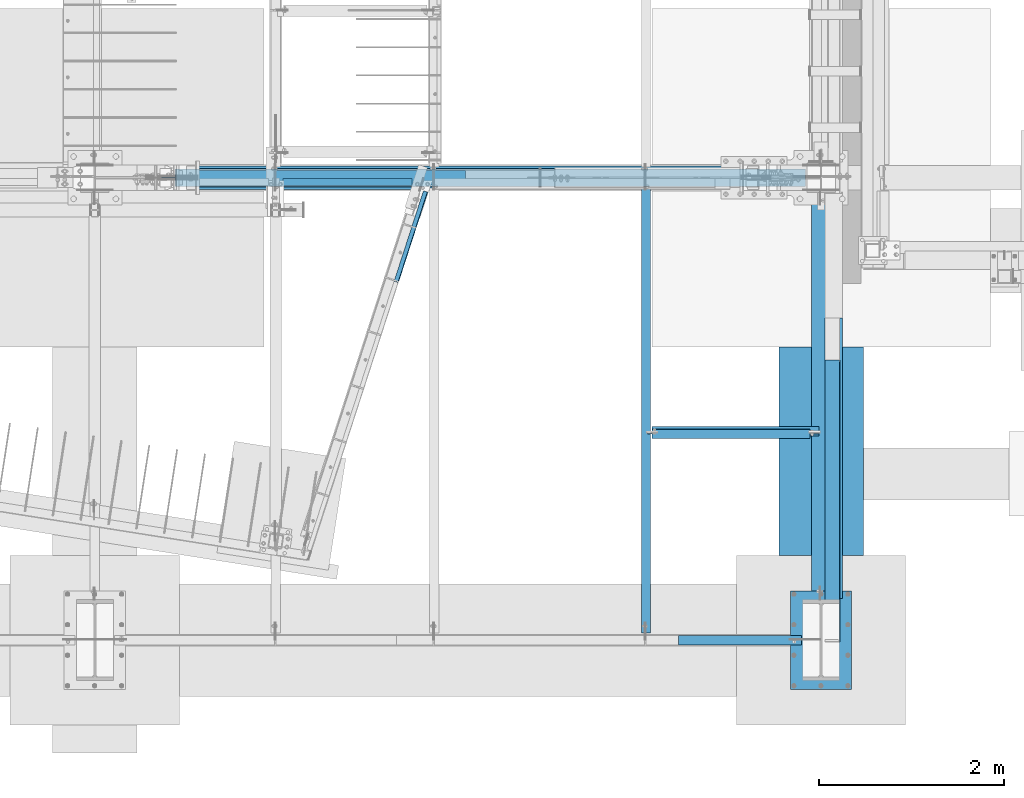
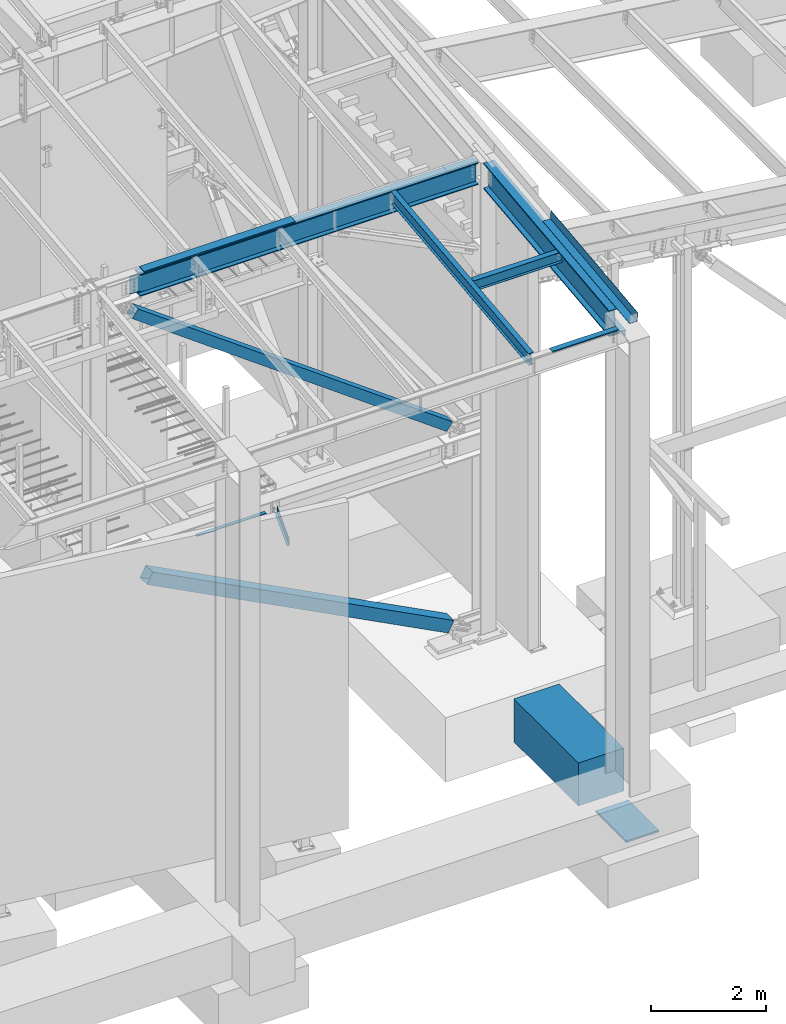
# One storey, part 715 of 1179: 12 beams, 2 members, 11 elements without a shape of their own.
"""IFC2X3 building model written with IfcOpenShell, lengths in millimetres."""

from ifc_helpers import new_model, si_unit, frame, origin_with_axes, place, context, subcontext, project, spatial, faceted_brep, material, type_object, element, aggregate, save


model = new_model("IFC2X3")

# Units and contexts
model_context = context("Model", 3, precision=1e-05, world=origin_with_axes())
body_context = subcontext(model_context, "Body", "Model", "MODEL_VIEW")
ifc_project = project(units=[si_unit("LENGTHUNIT", "METRE", prefix="MILLI"), si_unit("AREAUNIT", "SQUARE_METRE"), si_unit("VOLUMEUNIT", "CUBIC_METRE"), si_unit("MASSUNIT", "GRAM", prefix="KILO"), si_unit("TIMEUNIT", "SECOND"), si_unit("PLANEANGLEUNIT", "RADIAN"), si_unit("SOLIDANGLEUNIT", "STERADIAN"), si_unit("THERMODYNAMICTEMPERATUREUNIT", "DEGREE_CELSIUS"), si_unit("LUMINOUSINTENSITYUNIT", "LUMEN")], contexts=[model_context])

# Site, building, storey
site_placement = place(None, origin_with_axes())
site = spatial("IfcSite", under=ifc_project, at=site_placement, CompositionType="ELEMENT")
building_placement = place(site_placement, origin_with_axes())
building = spatial("IfcBuilding", under=site, at=building_placement, Name="Undefined", CompositionType="ELEMENT")
storey_placement = place(building_placement, origin_with_axes())
storey = spatial("IfcBuildingStorey", under=building, at=storey_placement, Name="Undefined", CompositionType="ELEMENT", Elevation=0.0)

# Assembly, beam
assembly_1_placement = place(storey_placement, origin_with_axes())
assembly_1 = element("IfcElementAssembly", 1, at=assembly_1_placement, inside=storey, Name="BEAM", AssemblyPlace="NOTDEFINED", PredefinedType="RIGID_FRAME")
ifc_material_1 = material(Name="STEEL/A36")
beam_type_1 = type_object("IfcBeamType", PredefinedType="NOTDEFINED")
beam_1_placement = place(assembly_1_placement, frame((18943.6380023565, 5508.63433466315, 9826.91628425202), z_axis=(-1.0, 0.0, 0.0), x_axis=(0.0, 0.0, 1.0)))
beam_1 = element("IfcBeam", 2, at=beam_1_placement, type_object=beam_type_1, material=ifc_material_1, Name="BENT_PLATE", context=body_context, shape_type="Brep", body=[
    faceted_brep([(-2.91038304567337e-11, -4.76250000000073, -1524.0), (-2.91038304567337e-11, -4.76250000000073, 1524.0), (2.91038304567337e-11, 4.76250000000073, 1524.0), (2.91038304567337e-11, 4.76250000000073, -1524.0), (42.9704233942375, 4.76249999974698, 1524.0), (42.9704233942375, 4.76249999974698, -1524.0), (32.3091293704474, -4.7625000001899, -1524.0), (32.3091293704474, -4.7625000001899, 1524.0), (25.4000000272608, -150.812499999743, 1524.0), (25.4000000272608, -150.812499999743, -1524.0), (16.8901864157524, -141.287499999744, -1524.0), (16.8901864157524, -141.287499999744, 1524.0), (8.54161044117063e-08, -150.812499999749, 1524.0), (8.54161044117063e-08, -150.812499999749, -1524.0), (8.54161044117063e-08, -141.287499999748, 1524.0), (8.54161044117063e-08, -141.287499999748, -1524.0)], [[[0, 1, 2, 3]], [[3, 2, 4, 5]], [[1, 0, 6, 7]], [[5, 4, 8, 9]], [[7, 6, 10, 11]], [[9, 8, 12, 13]], [[8, 4, 2, 1, 7, 11, 14, 12]], [[11, 10, 15, 14]], [[10, 6, 0, 3, 5, 9, 13, 15]], [[14, 15, 13, 12]]]),
])

assembly_2_placement = place(storey_placement, origin_with_axes())
assembly_2 = element("IfcElementAssembly", 3, at=assembly_2_placement, inside=storey, Name="BEAM", AssemblyPlace="NOTDEFINED", PredefinedType="RIGID_FRAME")
beam_type_2 = type_object("IfcBeamType", PredefinedType="NOTDEFINED")
beam_2_placement = place(assembly_2_placement, frame((19851.8875005852, 4805.93541535661, 3851.275), z_axis=(0.308737244064257, 0.951147367197958, 0.0), x_axis=(0.951147370126809, -0.30873723504115, 0.0)))
beam_2 = element("IfcBeam", 4, at=beam_2_placement, type_object=beam_type_2, material=ifc_material_1, Name="BENT_PLATE", context=body_context, shape_type="Brep", body=[
    faceted_brep([(-5.45696821063757e-11, -3.17500000000018, -514.350000000124), (6.18456397205591e-11, -3.17500000000018, 514.350000000128), (6.18456397205591e-11, 3.17500000000018, 514.350000000128), (-5.45696821063757e-11, 3.17500000000018, -514.350000000124), (50.8000003755697, 3.17500000000018, 514.35000000018), (50.8000003756788, 3.17500000000018, -514.350000000071), (44.4500003756766, -3.17500000000018, -514.350000000079), (44.4500003755638, -3.17500000000018, 514.350000000175), (50.8000003757079, -130.175006105127, 514.35000000021), (50.8000003755405, -130.17500610536, -514.350000000044), (44.4500003757021, -130.175006105127, 514.350000000204), (44.4500003755384, -130.17500610536, -514.350000000048)], [[[0, 1, 2, 3]], [[3, 2, 4, 5]], [[1, 0, 6, 7]], [[5, 4, 8, 9]], [[4, 2, 1, 7, 10, 8]], [[7, 6, 11, 10]], [[6, 0, 3, 5, 9, 11]], [[10, 11, 9, 8]]]),
])
aggregate(assembly_2, [beam_2])

assembly_3_placement = place(storey_placement, origin_with_axes())
assembly_3 = element("IfcElementAssembly", 5, at=assembly_3_placement, inside=storey, Name="BEAM", AssemblyPlace="NOTDEFINED", PredefinedType="RIGID_FRAME")
ifc_material_2 = material(Name="STEEL/A992")
beam_type_3 = type_object("IfcBeamType", Name="W10X12", PredefinedType="NOTDEFINED")
beam_3_placement = place(assembly_3_placement, frame((22415.5, 2681.08182806571, 9423.63694249416), z_axis=(0.0, -0.112284087038017, 0.993676146336441), x_axis=(1.0, 0.0, 0.0)))
beam_3 = element("IfcBeam", 6, at=beam_3_placement, type_object=beam_type_3, material=ifc_material_2, Name="BEAM", ObjectType="W10X12", context=body_context, shape_type="Brep", body=[
    faceted_brep([(14.2874999999985, -2.38124999999445, -103.187499998467), (14.2874999999985, 2.38125000000446, -103.187499998467), (50.8000001907421, 2.38125000000446, -103.18749999841), (50.8000001907421, -2.38124999999445, -103.187499998403), (55.6600797087885, 2.38125000000491, -104.154229920996), (55.6600797087885, -2.38124999999445, -104.154229920992), (59.7802561769422, 2.38125000000491, -106.907243821472), (59.7802561769422, -2.38124999999445, -106.907243821464), (62.5332700774197, 2.38125000000537, -111.027420289618), (62.5332700774197, -2.38124999999445, -111.027420289613), (63.5000000000073, -2.381249999994, -115.887499807652), (63.5000000000073, 2.38125000000537, -115.887499807655), (63.5000000000073, 2.38125000000537, -120.64999999994), (63.5000000000073, 50.8000000000006, -120.649999999963), (63.5000000000073, 50.8000000000006, -125.412499999959), (63.5000000000073, -50.7999999999884, -125.412499999913), (63.5000000000073, -50.7999999999888, -120.649999999914), (63.5000000000073, -2.381249999994, -120.649999999938), (147.63725, 50.7999999999897, 120.649999999914), (1773.2375, 50.7999999999897, 120.649999999914), (1773.2375, 2.38124999999445, 120.649999999938), (63.5000000000073, 2.38124999999445, 120.649999999938), (63.5000000000073, 50.7999999999897, 120.649999999914), (50.8000001907421, -2.381250000004, 103.187500001295), (50.8000001907421, 2.38124999999536, 103.18750000129), (14.2874999999985, 2.38124999999536, 103.187500001235), (14.2874999999985, -2.38125000000446, 103.187500001233), (55.6600797087885, -2.38125000000446, 104.154229923881), (55.6600797087885, 2.38124999999536, 104.154229923877), (59.7802561769422, -2.38125000000446, 106.907243824357), (59.7802561769422, 2.38124999999491, 106.907243824349), (62.5332700774197, -2.38125000000446, 111.027420292501), (62.5332700774197, 2.38124999999536, 111.027420292499), (63.5000000000073, -2.38125000000446, 115.88749981054), (63.5000000000073, 2.38124999999445, 115.887499810537), (1773.2375, -50.8000000000002, 125.41249999996), (1773.2375, 50.7999999999888, 125.412499999913), (63.5000000000073, 50.7999999999888, 125.412499999913), (63.5000000000073, -50.8000000000002, 125.41249999996), (1773.2375, -50.7999999999997, 120.649999999963), (63.5000000000073, -50.7999999999997, 120.649999999963), (1773.2375, -2.38125000000537, 120.64999999994), (63.5000000000073, -2.38125000000537, 120.64999999994), (1773.2375, -2.38125000000355, 100.012499809063), (1773.2375, 2.38124999999491, 100.012499809058), (1774.20422992259, -2.38125000000446, 95.1524202910259), (1774.20422992259, 2.38124999999536, 95.1524202910186), (1776.95724382307, -2.38125000000355, 91.0322438228777), (1776.95724382307, 2.38124999999627, 91.0322438228723), (1781.07742029122, -2.38125000000355, 88.2792299224038), (1781.07742029122, 2.38124999999582, 88.2792299223984), (1785.93749980927, -2.38125000000355, 87.3124999998163), (1785.93749980927, 2.38124999999536, 87.3124999998126), (1871.6625, -2.38125000000355, 87.3124999998727), (1871.6625, 2.38124999999536, 87.3124999998745), (1871.6625, -2.381249999994, -120.649999999938), (1871.6625, -50.7999999999888, -120.649999999914), (1871.6625, -50.7999999999884, -125.412499999913), (1871.6625, 50.8000000000006, -125.412499999959), (1871.6625, 50.8000000000006, -120.649999999963), (1871.6625, 2.38125000000537, -120.64999999994)], [[[0, 1, 2, 3]], [[3, 2, 4, 5]], [[5, 4, 6, 7]], [[7, 6, 8, 9]], [[10, 11, 12, 13, 14, 15, 16, 17]], [[9, 8, 11, 10]], [[18, 19, 20, 21, 22]], [[23, 24, 25, 26]], [[27, 28, 24, 23]], [[29, 30, 28, 27]], [[31, 32, 30, 29]], [[33, 34, 32, 31]], [[35, 36, 37, 38]], [[39, 35, 38, 40]], [[41, 39, 40, 42]], [[38, 37, 22, 21, 34, 33, 42, 40]], [[36, 19, 18, 22, 37]], [[35, 39, 41, 43, 44, 20, 19, 36]], [[45, 46, 44, 43]], [[47, 48, 46, 45]], [[49, 50, 48, 47]], [[51, 52, 50, 49]], [[53, 54, 52, 51]], [[55, 56, 57, 58, 59, 60, 54, 53]], [[56, 55, 17, 16]], [[57, 56, 16, 15]], [[58, 57, 15, 14]], [[59, 58, 14, 13]], [[60, 59, 13, 12]], [[6, 4, 2, 1, 25, 24, 28, 30, 32, 34, 21, 20, 44, 46, 48, 50, 52, 54, 60, 12, 11, 8]], [[26, 25, 1, 0]], [[55, 53, 51, 49, 47, 45, 43, 41, 42, 33, 31, 29, 27, 23, 26, 0, 3, 5, 7, 9, 10, 17]]]),
])
aggregate(assembly_3, [beam_3])

assembly_4_placement = place(storey_placement, origin_with_axes())
assembly_4 = element("IfcElementAssembly", 7, at=assembly_4_placement, inside=storey, Name="BEAM", AssemblyPlace="NOTDEFINED", PredefinedType="RIGID_FRAME")
beam_4_placement = place(assembly_4_placement, frame((22415.5, 452.231593993459, 9171.78056384809), z_axis=(-3.89779463887408e-08, -0.112282221021699, 0.993676357192035), x_axis=(0.0, 0.993676357192036, 0.112282221021699)))
beam_4 = element("IfcBeam", 8, at=beam_4_placement, type_object=beam_type_3, material=ifc_material_2, Name="BEAM", ObjectType="W10X12", context=body_context, shape_type="Brep", body=[
    faceted_brep([(4858.49015079339, 2.38124999999854, -120.649999999368), (4858.49015079341, 2.38119320135957, -125.412499999364), (4858.49013956012, 50.7999999999993, -125.412499999362), (4858.49013956012, 50.7999999999993, -120.649999999367), (4983.08589598448, 2.38124999999854, -120.649999999354), (4982.54774885665, 2.38122198294514, -125.412499999351), (48.8806597554974, -2.38124999999854, -120.649999999914), (48.8806597554974, -50.7999999999993, -120.649999999914), (4858.49016309746, -50.7999999999993, -120.649999999367), (4858.49015186424, -2.38124999999854, -120.649999999367), (76.1467808989316, 2.38124999999854, 120.649999999929), (76.1467808989316, 50.7999999999993, 120.649999999929), (4914.49585701086, 50.7999999999993, 120.650000000478), (4914.49585701086, 2.38124999999854, 120.650000000478), (48.3425126276663, -50.7999999999993, -125.412499999911), (76.1467808989316, -2.38124999999854, 120.649999999929), (76.1467808989316, -50.7999999999993, 120.649999999929), (76.6849280267622, -50.7999999999993, 125.412499999924), (76.6849280267622, 50.7999999999993, 125.412499999924), (48.8806597554974, 2.38124999999854, -120.649999999914), (48.8806597554974, 50.7999999999993, -120.649999999914), (48.3425126276663, 50.7999999999993, -125.412499999911), (4858.49016309746, -50.7999999999993, -125.412499999364), (4858.49015186426, -2.38130674932472, -125.412499999364), (4983.08589598448, -2.38124999999854, -120.649999999354), (4982.54774885665, -2.3812779679356, -125.412499999351), (4916.56631885514, -2.38124999999854, 69.1498492601459), (4912.78131142652, -2.38124999999854, 72.3480766489138), (4910.50832916744, -2.38124999999854, 76.7513131080195), (4910.0934130222, -2.38124999999854, 81.6892058020039), (4914.49585701086, -2.38124999999854, 120.650000000478), (4983.1719256045, -2.38124999999854, -119.888654181221), (5003.31510185873, -2.38124999999854, 58.3746347029464), (4921.28711838346, -2.38124999999854, 67.6435320696546), (4914.49585701086, -50.7999999999993, 120.650000000478), (4915.03400413869, -50.7999999999993, 125.412500000475), (4915.03400413869, 50.7999999999993, 125.412500000475), (4910.0934130222, 2.38124999999854, 81.6892058020039), (4910.50832916744, 2.38124999999854, 76.7513131080195), (4912.78131142652, 2.38124999999854, 72.3480766489138), (4916.56631885514, 2.38124999999854, 69.1498492601459), (4921.28711838346, 2.38124999999854, 67.6435320696546), (5003.31510185873, 2.38124999999854, 58.3746347029464), (4983.17191277243, 2.38124999999854, -119.888767742599)], [[[0, 1, 2, 3]], [[4, 5, 1, 0]], [[6, 7, 8, 9]], [[10, 11, 12, 13]], [[14, 7, 6, 15, 16, 17, 18, 11, 10, 19, 20, 21]], [[7, 14, 22, 8]], [[8, 22, 23, 9]], [[24, 9, 23, 25]], [[26, 27, 28, 29, 30, 15, 6, 9, 24, 31, 32, 33]], [[16, 15, 30, 34]], [[17, 16, 34, 35]], [[18, 17, 35, 36]], [[11, 18, 36, 12]], [[35, 34, 30, 29, 37, 13, 12, 36]], [[28, 38, 37, 29]], [[27, 39, 38, 28]], [[26, 40, 39, 27]], [[33, 41, 40, 26]], [[32, 42, 41, 33]], [[43, 4, 0, 19, 10, 13, 37, 38, 39, 40, 41, 42]], [[20, 19, 0, 3]], [[21, 20, 3, 2]], [[25, 23, 22, 14, 21, 2, 1, 5]], [[43, 42, 32, 31, 24, 25, 5, 4]]]),
])
aggregate(assembly_4, [beam_4])

assembly_5_placement = place(storey_placement, origin_with_axes())
assembly_5 = element("IfcElementAssembly", 9, at=assembly_5_placement, inside=storey, Name="BEAM", AssemblyPlace="NOTDEFINED", PredefinedType="RIGID_FRAME")
beam_type_4 = type_object("IfcBeamType", PredefinedType="NOTDEFINED")
beam_5_placement = place(assembly_5_placement, frame((24350.663, 1952.15627219184, 9470.67302837203), z_axis=(0.0, -0.993676357192036, -0.112282221021698), x_axis=(1.0, 0.0, 0.0)))
beam_5 = element("IfcBeam", 10, at=beam_5_placement, type_object=beam_type_4, material=ifc_material_1, Name="BENT_PLATE", context=body_context, shape_type="Brep", body=[
    faceted_brep([(0.0, -3.17499999999927, -1524.0), (6.00266503170133e-10, -3.17499999922438, 1524.00000000052), (6.00266503170133e-10, 3.17500000077416, 1524.00000000052), (0.0, 3.17499999999927, -1524.0), (153.987000024775, 3.17499999922438, 1524.00000000046), (153.987000022519, 3.17500000077052, -1524.00000000059), (160.337000000047, -3.17500000061591, -1523.99999999915), (160.336999999981, -3.17499999938082, 1523.99999999915), (153.987000000016, 187.325000000103, 1523.99999999907), (153.987000000016, 187.324999998867, -1523.99999999923), (160.337000000014, 187.325000000103, 1523.99999999907), (160.337000000014, 187.324999998867, -1523.99999999923)], [[[0, 1, 2, 3]], [[3, 2, 4, 5]], [[1, 0, 6, 7]], [[5, 4, 8, 9]], [[4, 2, 1, 7, 10, 8]], [[7, 6, 11, 10]], [[6, 0, 3, 5, 9, 11]], [[10, 11, 9, 8]]]),
])

# Assembly, member
assembly_6_placement = place(storey_placement, origin_with_axes())
assembly_6 = element("IfcElementAssembly", 11, at=assembly_6_placement, inside=storey, Name="None", AssemblyPlace="NOTDEFINED", PredefinedType="RIGID_FRAME")
member_type_1 = type_object("IfcMemberType", Name="HSS8X8X3/16", PredefinedType="NOTDEFINED")
member_1_placement = place(assembly_6_placement, frame((17229.9133529486, 5435.6, 9031.07902835531), z_axis=(0.0, -1.0, 0.0), x_axis=(0.807759850958799, 0.0, -0.589511681969932)))
member_1 = element("IfcMember", 12, at=member_1_placement, type_object=member_type_1, material=ifc_material_2, Name="None", ObjectType="HSS8X8X3/16", context=body_context, shape_type="Brep", body=[
    faceted_brep([(-3.63797880709171e-12, 96.8374999999978, -96.8375000000015), (-3.63797880709171e-12, -96.8374999999978, -96.8375000000015), (7834.63000001563, -96.8375000007909, -96.8374999999996), (7834.63000001565, 96.8374999992666, -96.8374999999996), (-3.63797880709171e-12, -96.8374999999978, 96.8375000000015), (7834.63000001563, -96.8375000007909, 96.8374999999996), (-3.63797880709171e-12, 96.8374999999978, 96.8375000000015), (7834.63000001565, 96.8374999992666, 96.8374999999996), (-3.63797880709171e-12, 101.599999999999, -101.599999999999), (-3.63797880709171e-12, 101.599999999999, 101.599999999999), (7834.63000001565, 101.599999999267, 101.6), (7834.63000001565, 101.599999999267, -101.6), (0.0, -101.599999999999, 101.599999999999), (7834.63000001562, -101.600000000792, 101.6), (0.0, -101.599999999999, -101.599999999999), (7834.63000001562, -101.600000000792, -101.6)], [[[0, 1, 2, 3]], [[1, 4, 5, 2]], [[4, 6, 7, 5]], [[6, 0, 3, 7]], [[8, 9, 10, 11]], [[9, 12, 13, 10]], [[12, 14, 15, 13]], [[14, 8, 11, 15]], [[13, 15, 11, 10], [5, 7, 3, 2]], [[14, 12, 9, 8], [6, 4, 1, 0]]]),
])
aggregate(assembly_6, [member_1])

# Beam
beam_type_5 = type_object("IfcBeamType", PredefinedType="NOTDEFINED")
beam_6_placement = place(assembly_5_placement, frame((24350.6629997969, 2403.71894899032, 8992.89453938396), z_axis=(0.0, -0.993676146336441, -0.112284087038017), x_axis=(1.0, 0.0, 0.0)))
beam_6 = element("IfcBeam", 13, at=beam_6_placement, type_object=beam_type_5, material=ifc_material_1, Name="BENT_PLATE", context=body_context, shape_type="Brep", body=[
    faceted_brep([(0.0, -3.17499999999927, -1524.0), (6.00266503170133e-10, -3.17499999922438, 1524.00000000052), (6.00266503170133e-10, 3.17500000077416, 1524.00000000052), (0.0, 3.17499999999927, -1524.0), (185.737000000001, 3.17499999999927, 1524.0), (185.737000000001, 3.17499999999927, -1524.0), (179.387000000001, -3.17499999999927, -1524.0), (179.387000000001, -3.17499999999927, 1524.0), (185.737000202938, -136.524999792508, 1523.99999999976), (185.737000202247, -136.524999793119, -1523.99999999991), (179.38700020294, -136.524999792508, 1523.99999999976), (179.387000202249, -136.524999793119, -1523.99999999991)], [[[0, 1, 2, 3]], [[3, 2, 4, 5]], [[1, 0, 6, 7]], [[5, 4, 8, 9]], [[4, 2, 1, 7, 10, 8]], [[7, 6, 11, 10]], [[6, 0, 3, 5, 9, 11]], [[10, 11, 9, 8]]]),
])

# Assembly, member
assembly_7_placement = place(storey_placement, origin_with_axes())
assembly_7 = element("IfcElementAssembly", 14, at=assembly_7_placement, inside=storey, Name="None", AssemblyPlace="NOTDEFINED", PredefinedType="RIGID_FRAME")
member_type_2 = type_object("IfcMemberType", Name="HSS10X10X1/4", PredefinedType="NOTDEFINED")
member_2_placement = place(assembly_7_placement, frame((23572.7953949511, 5435.6, 166.320234199969), z_axis=(0.0, 1.0, 0.0), x_axis=(-0.887207986876204, 0.0, 0.461369686935622)))
member_2 = element("IfcMember", 15, at=member_2_placement, type_object=member_type_2, material=ifc_material_2, Name="None", ObjectType="HSS10X10X1/4", context=body_context, shape_type="Brep", body=[
    faceted_brep([(-6.09361450187862e-11, 120.650000000031, -120.650000000001), (6.00266503170133e-11, -120.650000000031, -120.650000000001), (6829.34021817254, -120.650000005306, -120.65), (6829.34021817275, 120.649999994583, -120.65), (6.00266503170133e-11, -120.650000000031, 120.650000000001), (6829.34021817254, -120.650000005306, 120.65), (-6.09361450187862e-11, 120.650000000031, 120.650000000001), (6829.34021817275, 120.649999994583, 120.65), (-6.3664629124105e-11, 127.000000000032, -127.0), (-6.3664629124105e-11, 127.000000000032, 127.0), (6829.34021817276, 126.999999994581, 127.0), (6829.34021817276, 126.999999994581, -127.0), (6.2755134422332e-11, -127.000000000033, 127.0), (6829.34021817253, -127.000000005302, 127.0), (6.2755134422332e-11, -127.000000000033, -127.0), (6829.34021817253, -127.000000005302, -127.0)], [[[0, 1, 2, 3]], [[1, 4, 5, 2]], [[4, 6, 7, 5]], [[6, 0, 3, 7]], [[8, 9, 10, 11]], [[9, 12, 13, 10]], [[12, 14, 15, 13]], [[14, 8, 11, 15]], [[13, 15, 11, 10], [5, 7, 3, 2]], [[14, 12, 9, 8], [6, 4, 1, 0]]]),
])
aggregate(assembly_7, [member_2])

# Assembly, beam
assembly_8_placement = place(storey_placement, origin_with_axes())
assembly_8 = element("IfcElementAssembly", 16, at=assembly_8_placement, inside=storey, Name="BEAM", AssemblyPlace="NOTDEFINED", PredefinedType="RIGID_FRAME")
beam_type_6 = type_object("IfcBeamType", PredefinedType="NOTDEFINED")
beam_7_placement = place(assembly_8_placement, frame((23431.4999999992, 485.774999119926, 9265.25966887361), z_axis=(-1.0, 0.0, 0.0), x_axis=(0.0, 0.0, 1.0)))
beam_7 = element("IfcBeam", 17, at=beam_7_placement, type_object=beam_type_6, material=ifc_material_1, Name="BENT_PLATE", context=body_context, shape_type="Brep", body=[
    faceted_brep([(-2.18278728425503e-11, -3.17500000000001, -663.575), (-2.18278728425503e-11, -3.17500000000001, 663.575), (2.18278728425503e-11, 3.17500000000001, 663.575), (2.18278728425503e-11, 3.17500000000001, -663.575), (36.8806648298032, 3.17499999974928, 663.575), (36.8806648298032, 3.17499999974928, -663.575), (29.7727112124448, -3.17500000020243, -663.575), (29.7727112124448, -3.17500000020243, 663.575), (25.3999996229504, -98.4249984738682, 663.575), (25.3999996229504, -98.4249984738682, -663.575), (19.7271291780035, -92.0749984738682, -663.575), (19.7271291780035, -92.0749984738682, 663.575), (9.29503585211933e-09, -98.4249984738682, 663.575), (9.29503585211933e-09, -98.4249984738682, -663.575), (9.29503585211933e-09, -92.0749984738682, 663.575), (9.29503585211933e-09, -92.0749984738682, -663.575)], [[[0, 1, 2, 3]], [[3, 2, 4, 5]], [[1, 0, 6, 7]], [[5, 4, 8, 9]], [[7, 6, 10, 11]], [[9, 8, 12, 13]], [[8, 4, 2, 1, 7, 11, 14, 12]], [[11, 10, 15, 14]], [[10, 6, 0, 3, 5, 9, 13, 15]], [[14, 15, 13, 12]]]),
])
aggregate(assembly_8, [beam_7])

assembly_9_placement = place(storey_placement, origin_with_axes())
assembly_9 = element("IfcElementAssembly", 18, at=assembly_9_placement, inside=storey, Name="BEAM", AssemblyPlace="NOTDEFINED", PredefinedType="RIGID_FRAME")
beam_type_7 = type_object("IfcBeamType", PredefinedType="NOTDEFINED")
beam_8_placement = place(assembly_9_placement, frame((18491.2, 5390.35625, 3844.13071920033), z_axis=(0.0, 1.0, 0.0), x_axis=(1.0, 0.0, 0.0)))
beam_8 = element("IfcBeam", 19, at=beam_8_placement, type_object=beam_type_7, material=ifc_material_1, Name="PLATE", context=body_context, shape_type="Brep", body=[
    faceted_brep([(0.0, 3.96900000000005, -38.1000000000004), (0.0, 3.96900000000005, 38.1000000000004), (1394.48929206936, 3.96899999973493, 38.1000000000004), (1394.48929206936, 3.96899999973493, -38.1000000000004), (-3.63797880709171e-12, -3.96900000000005, 38.1000000000004), (1394.48929206935, -3.96900000026517, 38.1000000000004), (-3.63797880709171e-12, -3.96900000000005, -38.1000000000004), (1394.48929206935, -3.96900000026517, -38.1000000000004)], [[[0, 1, 2, 3]], [[1, 4, 5, 2]], [[4, 6, 7, 5]], [[6, 0, 3, 7]], [[5, 7, 3, 2]], [[6, 4, 1, 0]]]),
])
aggregate(assembly_9, [beam_8])

# Beam
beam_type_8 = type_object("IfcBeamType", Name="W18X65", PredefinedType="NOTDEFINED")
beam_9_placement = place(assembly_1_placement, frame((16459.2, 5435.60933465636, 9593.5537842795), z_axis=(0.0, 0.0, 1.0), x_axis=(1.0, 0.0, 0.0)))
beam_9 = element("IfcBeam", 20, at=beam_9_placement, type_object=beam_type_8, material=ifc_material_2, Name="BEAM", ObjectType="W18X65", context=body_context, shape_type="Brep", body=[
    faceted_brep([(878.763595283799, -96.8374999999996, 233.362499999999), (878.763595283799, 96.8374999999996, 233.362499999999), (867.765016111072, 96.8374999999996, 214.3125), (867.765016111072, 5.55624999999964, 214.3125), (867.535806875818, 5.55624999999964, 213.915499999999), (867.535806875818, -5.55624999999964, 213.915499999999), (867.765016111072, -5.55624999999964, 214.3125), (867.765016111072, -96.8374999999996, 214.3125), (910.628013754304, -5.55624999999964, 213.915499999999), (910.628013754304, 5.55624999999964, 213.915499999999), (925.204377951304, 5.55624999999964, 207.055856973129), (925.204377951304, -5.55624999999964, 207.055856973129), (929.060126560351, 5.55624999999964, 203.741552423035), (929.060126560351, -5.55624999999964, 203.741552423035), (930.661553035101, 5.55624999999964, 198.915907882363), (930.661553035101, -5.55624999999964, 198.915907882363), (929.552345954369, 5.55624999999964, 193.953945403768), (929.552345954369, -5.55624999999964, 193.953945403768), (926.048563449691, 5.55624999999964, 190.269529554975), (926.048563449691, -5.55624999999964, 190.269529554975), (921.148575411553, 5.55624999999964, 188.912500000002), (921.148575411553, -5.55624999999964, 188.912500000002), (718.540013754304, 5.55624999999964, 188.9125), (718.540013754304, -5.55624999999964, 188.9125), (718.540013754304, 5.55624999999964, -188.9125), (718.540013754304, -5.55624999999964, -188.9125), (921.492575411554, 5.55624999999964, -188.9125), (921.492575411554, -5.55624999999964, -188.9125), (926.392563449688, 5.55624999999964, -190.269529554975), (926.392563449688, -5.55624999999964, -190.269529554975), (929.89634595437, 5.55624999999964, -193.953945403768), (929.89634595437, -5.55624999999964, -193.953945403768), (931.005553035102, 5.55624999999964, -198.915907882363), (931.005553035102, -5.55624999999964, -198.915907882363), (929.404126560352, 5.55624999999964, -203.741552423035), (929.404126560352, -5.55624999999964, -203.741552423035), (925.548377951305, 5.55624999999964, -207.055856973127), (925.548377951305, -5.55624999999964, -207.055856973127), (910.972013754304, 5.55624999999964, -213.915499999999), (910.972013754304, -5.55624999999964, -213.915499999999), (878.992812523567, 5.55624999999964, -213.915499999999), (878.992812523567, -5.55624999999964, -213.915499999999), (7681.91250000001, 5.55624999999964, -214.3125), (7681.91250000001, 96.8374999999996, -214.3125), (878.763611292827, 96.8374999999996, -214.3125), (878.763611292827, 5.55624999999964, -214.3125), (7681.91250000001, 96.8374999999996, -233.362499999999), (7681.91250000001, -96.8374999999996, -233.362499999999), (867.765416215781, -96.8374999999996, -233.362499999999), (867.765416215781, 96.8374999999996, -233.362499999999), (7681.91250000001, -96.8374999999996, -214.3125), (878.763611292827, -96.8374999999996, -214.3125), (7681.91250000001, -5.55624999999964, -214.3125), (878.763611292827, -5.55624999999964, -214.3125), (7681.91250000001, 5.55624999999964, -129.327500000012), (7681.91250000001, 5.55624999999964, 189.652500000095), (7681.91250000001, 5.55624999999964, 214.3125), (7681.91250000001, 96.8374999999996, 214.3125), (7681.91250000001, 96.8374999999996, 233.362499999999), (7681.91250000001, -96.8374999999996, 233.362499999999), (7681.91250000001, -96.8374999999996, 214.3125), (7681.91250000001, -5.55624999999964, 214.3125)], [[[0, 1, 2, 3, 4, 5, 6, 7]], [[8, 9, 10, 11]], [[11, 10, 12, 13]], [[13, 12, 14, 15]], [[15, 14, 16, 17]], [[17, 16, 18, 19]], [[19, 18, 20, 21]], [[21, 20, 22, 23]], [[23, 22, 24, 25]], [[26, 27, 25, 24]], [[27, 26, 28, 29]], [[29, 28, 30, 31]], [[31, 30, 32, 33]], [[33, 32, 34, 35]], [[35, 34, 36, 37]], [[37, 36, 38, 39]], [[39, 38, 40, 41]], [[42, 43, 44, 45]], [[46, 47, 48, 49]], [[47, 50, 51, 48]], [[50, 52, 53, 51]], [[41, 40, 45, 44, 49, 48, 51, 53]], [[43, 46, 49, 44]], [[42, 54, 55, 56, 57, 58, 59, 60, 61, 52, 50, 47, 46, 43]], [[60, 59, 0, 7]], [[61, 60, 7, 6]], [[8, 11, 13, 15, 17, 19, 21, 23, 25, 27, 29, 31, 33, 35, 37, 39, 41, 53, 52, 61, 6, 5]], [[9, 8, 5, 4]], [[56, 55, 54, 42, 45, 40, 38, 36, 34, 32, 30, 28, 26, 24, 22, 20, 18, 16, 14, 12, 10, 9, 4, 3]], [[57, 56, 3, 2]], [[58, 57, 2, 1]], [[59, 58, 1, 0]]]),
])

aggregate(assembly_1, [beam_1, beam_9])

beam_type_9 = type_object("IfcBeamType", Name="W21X93", PredefinedType="NOTDEFINED")
beam_10_placement = place(assembly_5_placement, frame((24307.8, 468.986908190793, 9023.49921048305), z_axis=(-3.89779463887408e-08, -0.112282221021699, 0.993676357192035), x_axis=(0.0, 0.993676357192036, 0.112282221021699)))
beam_10 = element("IfcBeam", 21, at=beam_10_placement, type_object=beam_type_9, material=ifc_material_2, Name="BEAM", ObjectType="W21X93", context=body_context, shape_type="Brep", body=[
    faceted_brep([(391.652856100045, -106.362499999999, -274.63749999977), (391.652856100045, 106.362499999999, -274.63749999977), (4796.2434135006, 106.362499999999, -274.637499999269), (4796.2434135006, -106.362499999999, -274.637499999269), (394.3435917392, -106.362499999999, -250.824999999786), (394.3435917392, -7.14374999999927, -250.824999999786), (451.028422537392, -7.14374999999927, 250.824999999882), (451.028422537392, -106.362499999999, 250.824999999882), (453.719158176547, -106.362499999999, 274.637499999868), (453.719158176547, 106.362499999999, 274.637499999868), (451.028422537392, 106.362499999999, 250.824999999882), (451.028422537392, 7.14374999999927, 250.824999999882), (447.483428413096, 7.14374999999927, 219.452474450976), (404.47933776177, 7.14374999999927, -161.125570353066), (394.3435917392, 7.14374999999927, -250.824999999786), (394.3435917392, 106.362499999999, -250.824999999786), (4798.93414913976, -106.362499999999, -250.824999999288), (4798.93414913976, -7.14374999999927, -250.824999999288), (4855.61897993795, -7.14374999999927, 250.825000000383), (4855.61897993795, -106.362499999999, 250.825000000383), (4858.3097155771, -106.362499999999, 274.637500000368), (4858.3097155771, 106.362499999999, 274.637500000368), (4855.61897993795, 106.362499999999, 250.825000000383), (4855.61897993795, 7.14374999999927, 250.825000000383), (4798.93414913976, 7.14374999999927, -250.824999999288), (4798.93414913976, 106.362499999999, -250.824999999288)], [[[0, 1, 2, 3]], [[0, 4, 5, 6, 7, 8, 9, 10, 11, 12, 13, 14, 15, 1]], [[5, 4, 16, 17]], [[6, 5, 17, 18]], [[7, 6, 18, 19]], [[8, 7, 19, 20]], [[9, 8, 20, 21]], [[10, 9, 21, 22]], [[11, 10, 22, 23]], [[14, 13, 12, 11, 23, 24]], [[15, 14, 24, 25]], [[1, 15, 25, 2]], [[24, 23, 22, 21, 20, 19, 18, 17, 16, 3, 2, 25]], [[4, 0, 3, 16]]]),
])

aggregate(assembly_5, [beam_6, beam_5, beam_10])

# Assembly, beam
assembly_10_placement = place(storey_placement, origin_with_axes())
assembly_10 = element("IfcElementAssembly", 22, at=assembly_10_placement, inside=storey, Name="GRADE_BEAM", AssemblyPlace="NOTDEFINED", PredefinedType="REINFORCEMENT_UNIT")
ifc_material_3 = material(Name="CONCRETE/5000")
beam_type_10 = type_object("IfcBeamType", PredefinedType="NOTDEFINED")
beam_11_placement = place(assembly_10_placement, frame((24307.8, 1352.55, -889.0), z_axis=(0.0, 0.0, 1.0), x_axis=(0.0, 1.0, 0.0)))
beam_11 = element("IfcBeam", 23, at=beam_11_placement, type_object=beam_type_10, material=ifc_material_3, Name="GRADE_BEAM", context=body_context, shape_type="Brep", body=[
    faceted_brep([(4.84305928694084e-11, 457.2, -457.2), (4.84305928694084e-11, 457.2, 457.2), (2254.25, 457.200000000001, 457.2), (2254.25, 457.200000000001, -457.2), (-4.82032191939652e-11, -457.2, 457.2), (2254.25, -457.200000000001, 457.2), (-4.82032191939652e-11, -457.2, -457.2), (2254.25, -457.200000000001, -457.2)], [[[0, 1, 2, 3]], [[1, 4, 5, 2]], [[4, 6, 7, 5]], [[6, 0, 3, 7]], [[5, 7, 3, 2]], [[6, 4, 1, 0]]]),
])
aggregate(assembly_10, [beam_11])

assembly_11_placement = place(storey_placement, origin_with_axes())
assembly_11 = element("IfcElementAssembly", 24, at=assembly_11_placement, inside=storey, Name="COLUMN", AssemblyPlace="NOTDEFINED", PredefinedType="RIGID_FRAME")
ifc_material_4 = material(Name="STEEL/A572-GR.50")
beam_type_11 = type_object("IfcBeamType", PredefinedType="NOTDEFINED")
beam_12_placement = place(assembly_11_placement, frame((24307.8, -95.25, -1276.35), z_axis=(-1.0, 0.0, 0.0), x_axis=(0.0, 1.0, 0.0)))
beam_12 = element("IfcBeam", 25, at=beam_12_placement, type_object=beam_type_11, material=ifc_material_4, context=body_context, shape_type="Brep", body=[
    faceted_brep([(0.0, 19.05, -330.200000000001), (0.0, 19.05, 330.2), (1066.80000000029, 19.05, 330.2), (1066.80000000029, 19.05, -330.200000000001), (0.0, -19.05, 330.2), (1066.80000000029, -19.05, 330.2), (0.0, -19.05, -330.200000000001), (1066.80000000029, -19.05, -330.200000000001)], [[[0, 1, 2, 3]], [[1, 4, 5, 2]], [[4, 6, 7, 5]], [[6, 0, 3, 7]], [[5, 7, 3, 2]], [[6, 4, 1, 0]]]),
])
aggregate(assembly_11, [beam_12])

save(model, "model.ifc")
